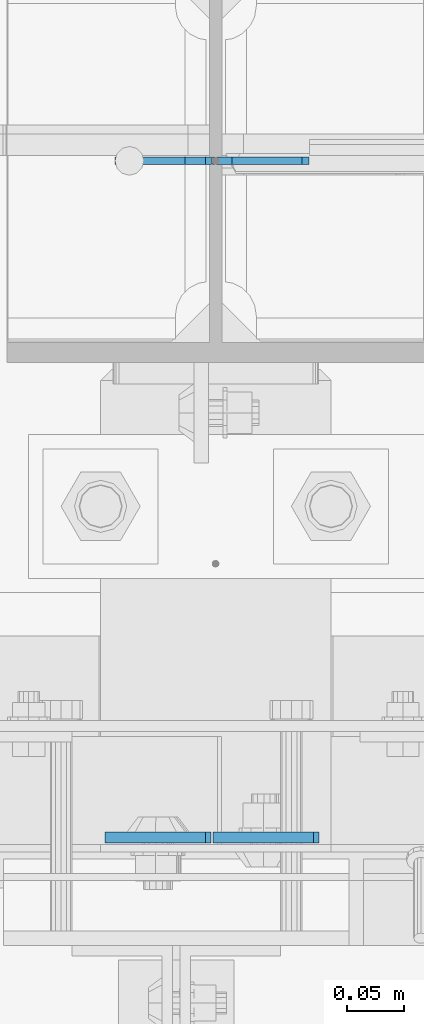
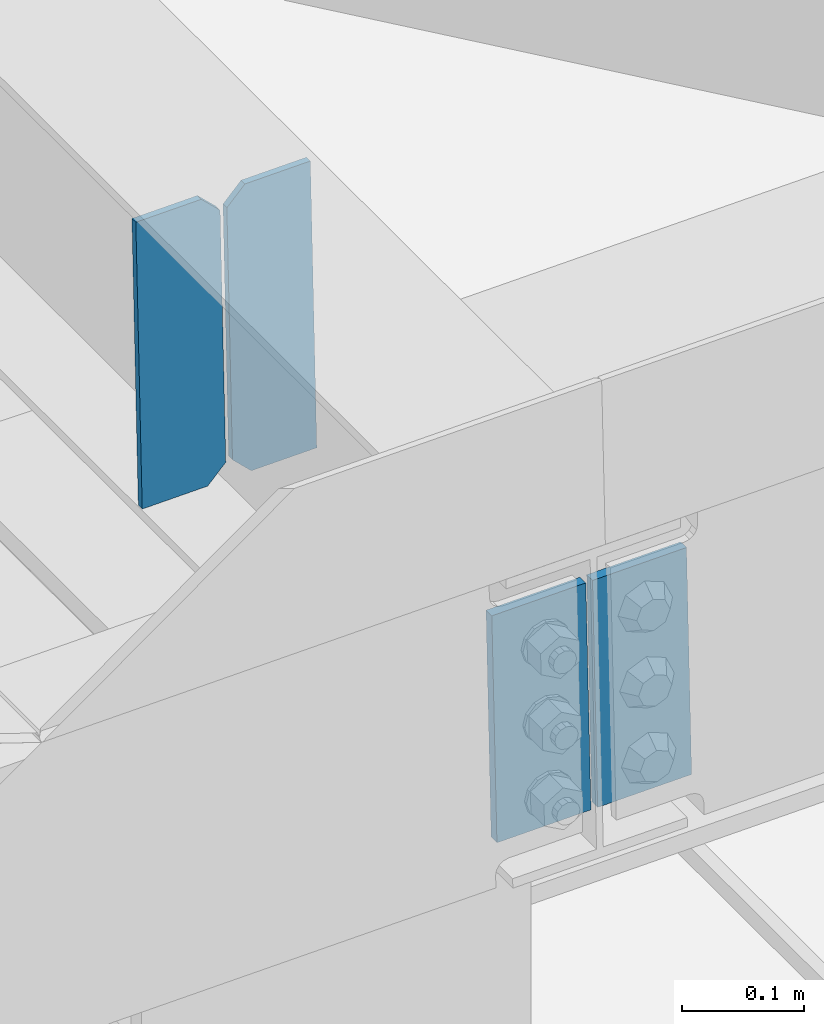
# One storey, part 3029 of 3843: 4 plates, 1 element without a shape of its own.
"""IFC2X3 building model written with IfcOpenShell, lengths in millimetres."""

from ifc_helpers import new_model, si_unit, frame, origin_with_axes, place, context, subcontext, project, spatial, faceted_brep, material, type_object, element, aggregate, save


model = new_model("IFC2X3")

# Units and contexts
model_context = context("Model", 3, precision=1e-05, world=origin_with_axes())
body_context = subcontext(model_context, "Body", "Model", "MODEL_VIEW")
ifc_project = project(units=[si_unit("LENGTHUNIT", "METRE", prefix="MILLI"), si_unit("AREAUNIT", "SQUARE_METRE"), si_unit("VOLUMEUNIT", "CUBIC_METRE"), si_unit("MASSUNIT", "GRAM", prefix="KILO"), si_unit("TIMEUNIT", "SECOND"), si_unit("PLANEANGLEUNIT", "RADIAN"), si_unit("SOLIDANGLEUNIT", "STERADIAN"), si_unit("THERMODYNAMICTEMPERATUREUNIT", "DEGREE_CELSIUS"), si_unit("LUMINOUSINTENSITYUNIT", "LUMEN")], contexts=[model_context])

# Site, building, storey
site_placement = place(None, origin_with_axes())
site = spatial("IfcSite", under=ifc_project, at=site_placement, CompositionType="ELEMENT")
building_placement = place(site_placement, origin_with_axes())
building = spatial("IfcBuilding", under=site, at=building_placement, Name="Undefined", CompositionType="ELEMENT")
storey_placement = place(building_placement, origin_with_axes())
storey = spatial("IfcBuildingStorey", under=building, at=storey_placement, Name="Undefined", CompositionType="ELEMENT", Elevation=0.0)

# Assembly, plates
assembly_placement = place(storey_placement, origin_with_axes())
assembly = element("IfcElementAssembly", 1, at=assembly_placement, inside=storey, Name="BEAM", AssemblyPlace="NOTDEFINED", PredefinedType="RIGID_FRAME")
ifc_material = material(Name="STEEL/A572-50")
plate_type_1 = type_object("IfcPlateType", PredefinedType="NOTDEFINED")
plate_1_placement = place(assembly_placement, frame((42059.7985991582, 25019.021947263, 45807.5059061531), z_axis=(0.999776269348333, -6.33400000515395e-06, 0.0211520970073762), x_axis=(0.0211520550054438, 0.0, -0.999776270257025)))
plate_1 = element("IfcPlate", 2, at=plate_1_placement, type_object=plate_type_1, material=ifc_material, Name="PLATE", context=body_context, shape_type="Brep", body=[
    faceted_brep([(0.0, -4.76249999999709, 0.0), (0.0, -4.76249999999709, 88.9000015258789), (0.0, 4.76249999999709, 88.9000015258789), (0.0, 4.76249999999709, 0.0), (228.600006102781, -4.7625000004191, 88.9000015257589), (228.600006102781, 4.76249999954598, 88.9000015257443), (228.600006103079, -4.7625000004482, 7.27595761418343e-12), (228.600006103079, 4.76249999954598, -7.27595761418343e-12)], [[[0, 1, 2, 3]], [[1, 4, 5, 2]], [[4, 6, 7, 5]], [[6, 0, 3, 7]], [[5, 7, 3, 2]], [[6, 4, 1, 0]]]),
])
plate_2_placement = place(assembly_placement, frame((42053.4499690524, 25018.9800052629, 45807.3715889939), z_axis=(-0.999776269348334, 6.33400000515396e-06, -0.0211520970073544), x_axis=(0.0211520550054438, 0.0, -0.999776270257025)))
plate_2 = element("IfcPlate", 3, at=plate_2_placement, type_object=plate_type_1, material=ifc_material, Name="PLATE", context=body_context, shape_type="Brep", body=[
    faceted_brep([(0.0, -4.76249999999709, 0.0), (0.0, -4.76249999999709, 88.9000015258789), (0.0, 4.76249999999709, 88.9000015258789), (0.0, 4.76249999999709, 0.0), (228.600006102781, -4.7625000004191, 88.9000015257589), (228.600006102781, 4.76249999954598, 88.9000015257443), (228.600006103079, -4.7625000004482, 7.27595761418343e-12), (228.600006103079, 4.76249999954598, -7.27595761418343e-12)], [[[0, 1, 2, 3]], [[1, 4, 5, 2]], [[4, 6, 7, 5]], [[6, 0, 3, 7]], [[5, 7, 3, 2]], [[6, 4, 1, 0]]]),
])
plate_type_2 = type_object("IfcPlateType", PredefinedType="NOTDEFINED")
plate_3_placement = place(assembly_placement, frame((42144.6964782621, 25615.9894894947, 45547.4885449991), z_axis=(-0.0211520979557463, -0.000299404999856052, 0.999776224516625), x_axis=(-0.999776269348334, 6.33400000515396e-06, -0.0211520970073544)))
plate_3 = element("IfcPlate", 4, at=plate_3_placement, type_object=plate_type_2, material=ifc_material, Name="STIFFENER", context=body_context, shape_type="Brep", body=[
    faceted_brep([(0.0, -3.17499999999927, 0.0), (6.83940015733242e-10, -3.17499999996653, 288.924999998613), (6.54836185276508e-10, 3.17500000001746, 288.924999998591), (0.0, 3.17499999999927, 0.0), (61.9125003828667, -3.17499999997744, 288.924999998599), (61.9125003828522, 3.17500000002838, 288.924999998584), (79.3750000013097, -3.17499999997744, 271.462500380039), (79.375000001266, 3.17500000002838, 271.462500380017), (79.375000000713, -3.17499999999927, 17.4624996185448), (79.3750000006694, 3.17500000000291, 17.462499618523), (61.9125003821828, -3.17499999999563, -1.45519152283669e-11), (61.9125003821682, 3.17500000000655, -2.91038304567337e-11)], [[[0, 1, 2, 3]], [[1, 4, 5, 2]], [[4, 6, 7, 5]], [[6, 8, 9, 7]], [[8, 10, 11, 9]], [[10, 0, 3, 11]], [[5, 7, 9, 11, 3, 2]], [[10, 8, 6, 4, 1, 0]]]),
])
plate_4_placement = place(assembly_placement, frame((42058.9906575725, 25615.9900325162, 45545.6752814801), z_axis=(-0.0211520979557463, -0.000299404999856052, 0.999776224516625), x_axis=(-0.999776269348334, 6.33400000515396e-06, -0.0211520970073544)))
plate_4 = element("IfcPlate", 5, at=plate_4_placement, type_object=plate_type_2, material=ifc_material, Name="STIFFENER", context=body_context, shape_type="Brep", body=[
    faceted_brep([(5.82076609134674e-11, -3.17499999999927, 17.4624996185667), (6.25732354819775e-10, -3.17499999997744, 271.462500380054), (5.82076609134674e-10, 3.17500000002474, 271.462500380039), (0.0, 3.17500000000655, 17.4624996185521), (17.462499619156, -3.17499999997744, 288.924999998606), (17.4624996191269, 3.17500000002474, 288.924999998591), (79.3750000013242, -3.17500000025029, 288.924999998591), (79.3750000013097, 3.1749999997337, 288.92499999857), (79.3750000006548, -3.17500000026484, -2.18278728425503e-11), (79.3750000006403, 3.17499999969732, -2.91038304567337e-11), (17.4624996184866, -3.17500000000291, 7.27595761418343e-12), (17.462499618443, 3.17500000000291, -7.27595761418343e-12)], [[[0, 1, 2, 3]], [[1, 4, 5, 2]], [[4, 6, 7, 5]], [[6, 8, 9, 7]], [[8, 10, 11, 9]], [[10, 0, 3, 11]], [[5, 7, 9, 11, 3, 2]], [[10, 8, 6, 4, 1, 0]]]),
])
aggregate(assembly, [plate_1, plate_2, plate_3, plate_4])

save(model, "model.ifc")
